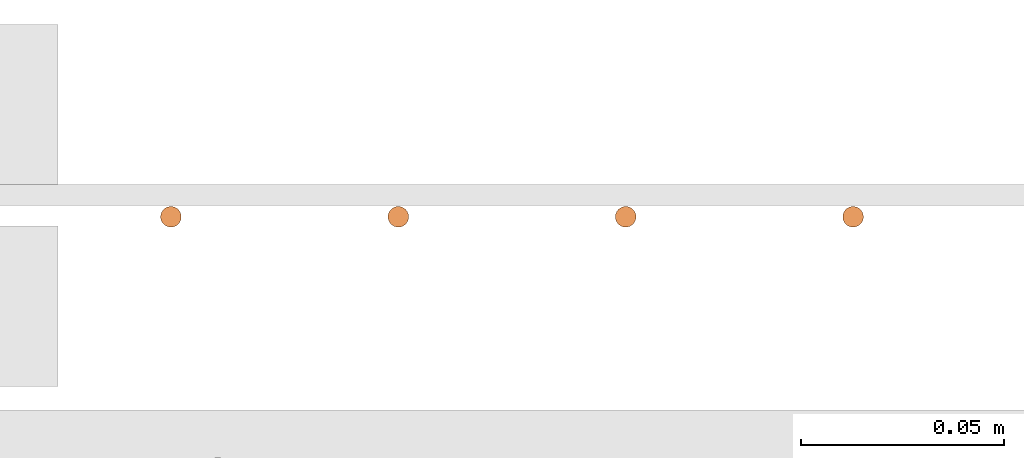
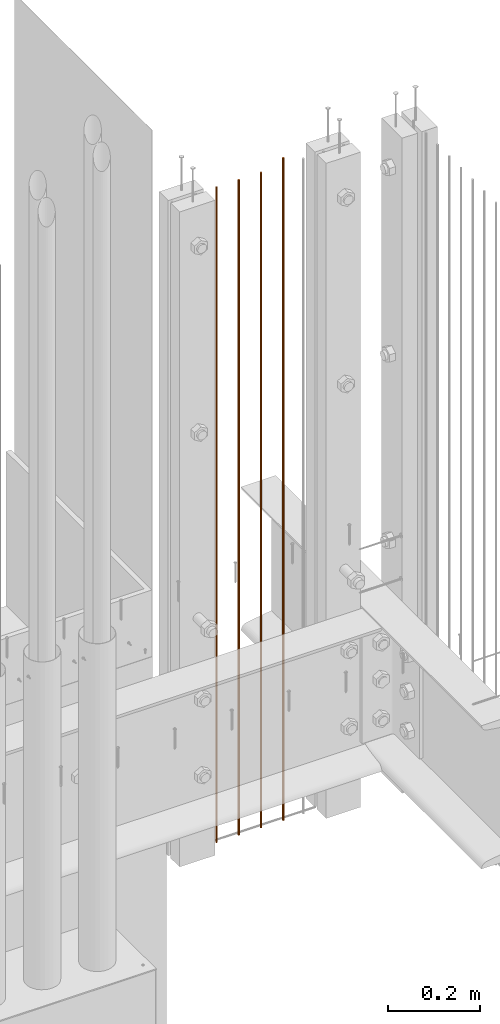
# One storey, part 8 of 44: 4 proxies.
"""IFC4 building model written with IfcOpenShell, lengths in feet."""

from ifc_helpers import new_model, entity, si_unit, converted_unit, derived_unit, direction, frame, origin, origin_2d_with_axis, place, context, subcontext, project, spatial, circle, extrude, source, transform, mapped, material, type_object, type_shapes, element, save


model = new_model("IFC4")

# Units and contexts
model_context = context("Model", 3, precision=0.0001, world=origin(), true_north=direction((6.12303176911189e-17, 1.0)))
body_context = subcontext(model_context, "Body", "Model", "MODEL_VIEW")
ifc_project = project(units=[converted_unit("LENGTHUNIT", "FOOT", entity("IfcRatioMeasure", 0.3048), si_unit("LENGTHUNIT", "METRE"), dimensions=[1, 0, 0, 0, 0, 0, 0]), converted_unit("AREAUNIT", "SQUARE FOOT", entity("IfcRatioMeasure", 0.09290304), si_unit("AREAUNIT", "SQUARE_METRE"), dimensions=[2, 0, 0, 0, 0, 0, 0]), converted_unit("VOLUMEUNIT", "CUBIC FOOT", entity("IfcRatioMeasure", 0.028316846592), si_unit("VOLUMEUNIT", "CUBIC_METRE"), dimensions=[3, 0, 0, 0, 0, 0, 0]), converted_unit("PLANEANGLEUNIT", "DEGREE", entity("IfcRatioMeasure", 0.0174532925199433), si_unit("PLANEANGLEUNIT", "RADIAN"), dimensions=[0, 0, 0, 0, 0, 0, 0]), si_unit("MASSUNIT", "GRAM", prefix="KILO"), derived_unit("MASSDENSITYUNIT", [(si_unit("MASSUNIT", "GRAM", prefix="KILO"), 1), (si_unit("LENGTHUNIT", "METRE"), -3)]), derived_unit("MOMENTOFINERTIAUNIT", [(si_unit("LENGTHUNIT", "METRE"), 4)]), si_unit("TIMEUNIT", "SECOND"), si_unit("FREQUENCYUNIT", "HERTZ"), si_unit("THERMODYNAMICTEMPERATUREUNIT", "DEGREE_CELSIUS"), derived_unit("THERMALTRANSMITTANCEUNIT", [(si_unit("MASSUNIT", "GRAM", prefix="KILO"), 1), (si_unit("THERMODYNAMICTEMPERATUREUNIT", "KELVIN"), -1), (si_unit("TIMEUNIT", "SECOND"), -3)]), derived_unit("VOLUMETRICFLOWRATEUNIT", [(si_unit("LENGTHUNIT", "METRE"), 3), (si_unit("TIMEUNIT", "SECOND"), -1)]), si_unit("ELECTRICCURRENTUNIT", "AMPERE"), si_unit("ELECTRICVOLTAGEUNIT", "VOLT"), si_unit("POWERUNIT", "WATT"), si_unit("FORCEUNIT", "NEWTON"), si_unit("ILLUMINANCEUNIT", "LUX"), si_unit("LUMINOUSFLUXUNIT", "LUMEN"), si_unit("LUMINOUSINTENSITYUNIT", "CANDELA"), derived_unit("USERDEFINED", [(si_unit("MASSUNIT", "GRAM", prefix="KILO"), -1), (si_unit("LENGTHUNIT", "METRE"), -2), (si_unit("TIMEUNIT", "SECOND"), 3), (si_unit("LUMINOUSFLUXUNIT", "LUMEN"), 1)]), derived_unit("LINEARVELOCITYUNIT", [(si_unit("LENGTHUNIT", "METRE"), 1), (si_unit("TIMEUNIT", "SECOND"), -1)]), si_unit("PRESSUREUNIT", "PASCAL"), derived_unit("USERDEFINED", [(si_unit("LENGTHUNIT", "METRE"), -2), (si_unit("MASSUNIT", "GRAM", prefix="KILO"), 1), (si_unit("TIMEUNIT", "SECOND"), -2)]), derived_unit("LINEARFORCEUNIT", [(si_unit("MASSUNIT", "GRAM", prefix="KILO"), 1), (si_unit("LENGTHUNIT", "METRE"), 1), (si_unit("TIMEUNIT", "SECOND"), -2), (si_unit("LENGTHUNIT", "METRE"), -1)]), derived_unit("PLANARFORCEUNIT", [(si_unit("MASSUNIT", "GRAM", prefix="KILO"), 1), (si_unit("LENGTHUNIT", "METRE"), 1), (si_unit("TIMEUNIT", "SECOND"), -2), (si_unit("LENGTHUNIT", "METRE"), -2)])], contexts=[model_context])

# Site, building, storey
site_placement = place(None, origin())
site = spatial("IfcSite", under=ifc_project, at=site_placement, CompositionType="ELEMENT")
building_placement = place(site_placement, origin())
building = spatial("IfcBuilding", under=site, at=building_placement, CompositionType="ELEMENT")
storey_placement = place(building_placement, origin())
storey = spatial("IfcBuildingStorey", under=building, at=storey_placement, CompositionType="ELEMENT", Elevation=0.0)

# Proxies
ifc_material = material(Category="Materials")
building_element_proxy_type_1 = type_object("IfcBuildingElementProxyType", Name="RAILING 30:RAILING 20", PredefinedType="NOTDEFINED", material=ifc_material)
shared_shape_1 = source(origin(), body_context, "Body", "SweptSolid", [
    extrude(circle(Radius=0.00833333333333333, at=origin_2d_with_axis()), frame((0.013567166128496, 0.0135671661283334, 0.0)), (0.0, 0.0, 1.0), 5.70833333333334),
])
type_shapes(building_element_proxy_type_1, [shared_shape_1])
proxy_1_placement = place(storey_placement, frame((1492.87797445179, 4.88094253557483, 8.17708333333332)))
element("IfcBuildingElementProxy", 1, at=proxy_1_placement, inside=storey, type_object=building_element_proxy_type_1, material=ifc_material, Name="RAILING 30:RAILING 20", ObjectType="RAILING 30:RAILING 20", PredefinedType="NOTDEFINED", context=body_context, shape_type="MappedRepresentation", body=[
    mapped(shared_shape_1, transform((0.0, 0.0, 0.0), scale=1.0)),
])
building_element_proxy_type_2 = type_object("IfcBuildingElementProxyType", Name="RAILING 31:RAILING 20", PredefinedType="NOTDEFINED", material=ifc_material)
shared_shape_2 = source(origin(), body_context, "Body", "SweptSolid", [
    extrude(circle(Radius=0.00833333333333333, at=origin_2d_with_axis()), frame((0.013567166128496, 0.0135671661283334, 0.0)), (0.0, 0.0, 1.0), 5.70833333333334),
])
type_shapes(building_element_proxy_type_2, [shared_shape_2])
proxy_2_placement = place(storey_placement, frame((1493.06130778512, 4.88094253557483, 8.17708333333332)))
element("IfcBuildingElementProxy", 2, at=proxy_2_placement, inside=storey, type_object=building_element_proxy_type_2, material=ifc_material, Name="RAILING 31:RAILING 20", ObjectType="RAILING 31:RAILING 20", PredefinedType="NOTDEFINED", context=body_context, shape_type="MappedRepresentation", body=[
    mapped(shared_shape_2, transform((0.0, 0.0, 0.0), scale=1.0)),
])
building_element_proxy_type_3 = type_object("IfcBuildingElementProxyType", Name="RAILING 32:RAILING 20", PredefinedType="NOTDEFINED", material=ifc_material)
shared_shape_3 = source(origin(), body_context, "Body", "SweptSolid", [
    extrude(circle(Radius=0.00833333333333333, at=origin_2d_with_axis()), frame((0.013567166128496, 0.0135671661283334, 0.0)), (0.0, 0.0, 1.0), 5.70833333333334),
])
type_shapes(building_element_proxy_type_3, [shared_shape_3])
proxy_3_placement = place(storey_placement, frame((1493.24464111846, 4.88094253557483, 8.17708333333332)))
element("IfcBuildingElementProxy", 3, at=proxy_3_placement, inside=storey, type_object=building_element_proxy_type_3, material=ifc_material, Name="RAILING 32:RAILING 20", ObjectType="RAILING 32:RAILING 20", PredefinedType="NOTDEFINED", context=body_context, shape_type="MappedRepresentation", body=[
    mapped(shared_shape_3, transform((0.0, 0.0, 0.0), scale=1.0)),
])
building_element_proxy_type_4 = type_object("IfcBuildingElementProxyType", Name="RAILING 33:RAILING 20", PredefinedType="NOTDEFINED", material=ifc_material)
shared_shape_4 = source(origin(), body_context, "Body", "SweptSolid", [
    extrude(circle(Radius=0.00833333333333333, at=origin_2d_with_axis()), frame((0.013567166128496, 0.0135671661283334, 0.0)), (0.0, 0.0, 1.0), 5.77083333333334),
])
type_shapes(building_element_proxy_type_4, [shared_shape_4])
proxy_4_placement = place(storey_placement, frame((1493.42797445179, 4.88094253557483, 8.17708333333333)))
element("IfcBuildingElementProxy", 4, at=proxy_4_placement, inside=storey, type_object=building_element_proxy_type_4, material=ifc_material, Name="RAILING 33:RAILING 20", ObjectType="RAILING 33:RAILING 20", PredefinedType="NOTDEFINED", context=body_context, shape_type="MappedRepresentation", body=[
    mapped(shared_shape_4, transform((0.0, 0.0, 0.0), scale=1.0)),
])

save(model, "model.ifc")
